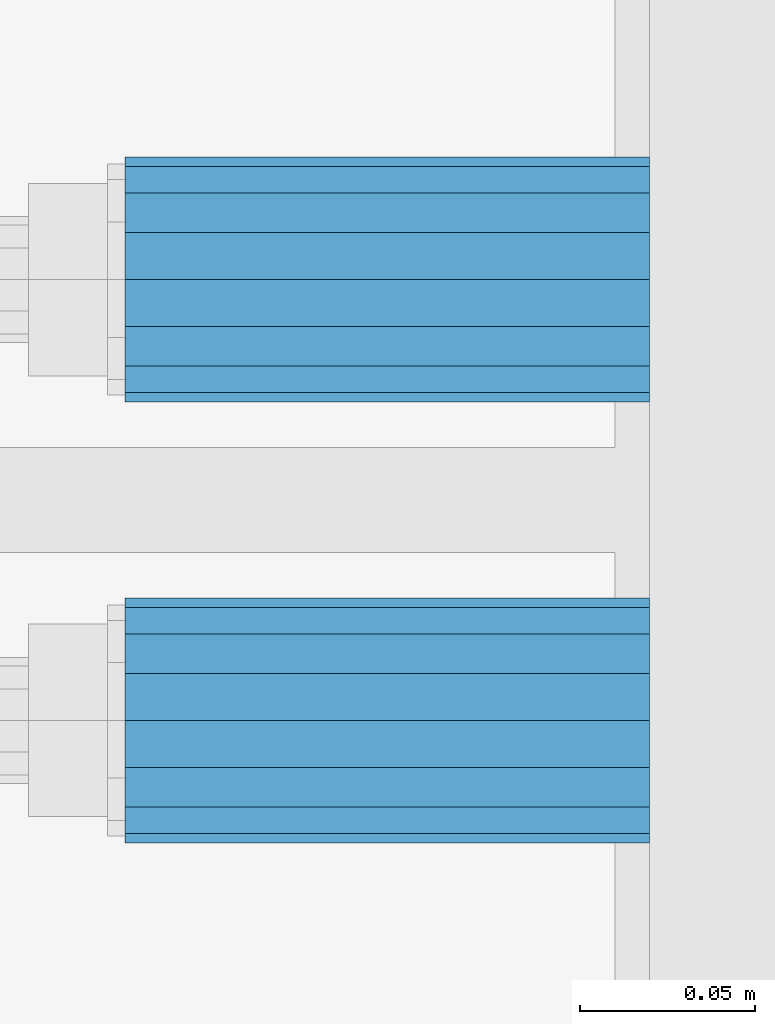
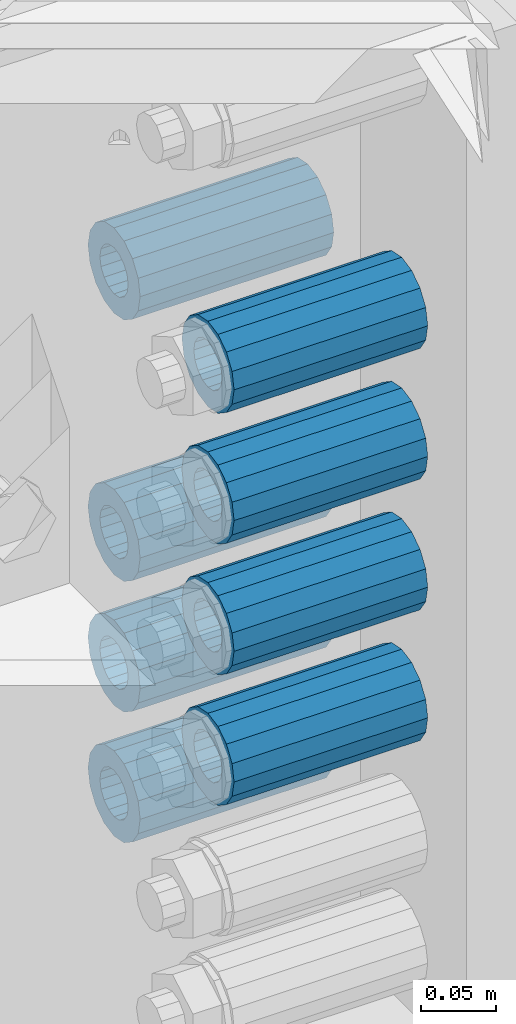
# One storey, part 133 of 208: 8 beams.
"""IFC2X3 building model written with IfcOpenShell, lengths in millimetres."""

import ifcopenshell
import ifcopenshell.guid

model = None  # the IFC model being written
_history = None  # IfcOwnerHistory: only IFC2X3 demands one
_inside = {}  # id of a spatial element -> (the spatial element, [elements in it])
_under = {}  # id of a project, library or spatial element -> (it, [spatial elements below it])
_declared = {}  # id of a project -> (the project, [libraries it declares])
_typed = {}  # id of a type object -> (the type object, [elements of that type])
_made_of = {}  # id of a material, layer set ... -> (it, [elements and type objects made of it])


def new_model(schema):
    """Start an empty IFC model of exactly this schema.

    Asked for "IFC4X3", IfcOpenShell would pick the latest addendum, in which some entities
    have other attributes; the version numbers below select the first issue.
    IFC2X3 requires an IfcOwnerHistory on every rooted entity: one is made here for all.
    """
    global model, _history
    if schema == "IFC4X3":
        model = ifcopenshell.file(schema_version=(4, 3, 0, 0))
    else:
        model = ifcopenshell.file(schema=schema)
    _inside.clear()
    _under.clear()
    _declared.clear()
    _typed.clear()
    _made_of.clear()
    _history = None
    if model.schema == "IFC2X3":
        org = make("IfcOrganization", Name="unknown")
        user = make(
            "IfcPersonAndOrganization",
            ThePerson=make("IfcPerson", FamilyName="unknown"),
            TheOrganization=org,
        )
        app = make(
            "IfcApplication",
            ApplicationDeveloper=org,
            Version="unknown",
            ApplicationFullName="unknown",
            ApplicationIdentifier="unknown",
        )
        _history = make(
            "IfcOwnerHistory",
            OwningUser=user,
            OwningApplication=app,
            ChangeAction="ADDED",
            CreationDate=0,
        )
    return model


def make(cls, **values):
    """One entity of the class cls with the attributes given. An attribute that is None is left unset."""
    return model.create_entity(
        cls, **{name: value for name, value in values.items() if value is not None}
    )


def rooted(cls, **values):
    """An entity with a GlobalId (a new one), such as an element, a storey or a relation."""
    return make(cls, GlobalId=ifcopenshell.guid.new(), OwnerHistory=_history, **values)


def si_unit(unit_type, name, prefix=None):
    """IfcSIUnit, for example si_unit("LENGTHUNIT", "METRE", prefix="MILLI")."""
    return make("IfcSIUnit", UnitType=unit_type, Prefix=prefix, Name=name)


def assignment(units):
    """IfcUnitAssignment: the units of a project."""
    return None if units is None else make("IfcUnitAssignment", Units=units)


def point(xyz):
    """IfcCartesianPoint."""
    return None if xyz is None else make("IfcCartesianPoint", Coordinates=xyz)


def direction(xyz):
    """IfcDirection."""
    return None if xyz is None else make("IfcDirection", DirectionRatios=xyz)


def frame(location, z_axis=None, x_axis=None):
    """IfcAxis2Placement3D, a coordinate frame: its origin and axes. An axis left out is left unset."""
    return make(
        "IfcAxis2Placement3D",
        Location=point(location),
        Axis=direction(z_axis),
        RefDirection=direction(x_axis),
    )


def origin_with_axes():
    """The frame at (0, 0, 0) with the z axis (0, 0, 1) and the x axis (1, 0, 0) written out."""
    return frame((0.0, 0.0, 0.0), z_axis=(0.0, 0.0, 1.0), x_axis=(1.0, 0.0, 0.0))


def place(relative_to, where):
    """IfcLocalPlacement: puts the frame where relative to a parent placement (None: the world)."""
    return make(
        "IfcLocalPlacement", PlacementRelTo=relative_to, RelativePlacement=where
    )


def context(
    kind, dimensions, precision=None, world=None, true_north=None, identifier=None
):
    """IfcGeometricRepresentationContext, for example the 3D "Model" context."""
    return make(
        "IfcGeometricRepresentationContext",
        ContextIdentifier=identifier,
        ContextType=kind,
        CoordinateSpaceDimension=dimensions,
        Precision=precision,
        WorldCoordinateSystem=world,
        TrueNorth=true_north,
    )


def subcontext(parent, identifier, kind, view, scale=None):
    """IfcGeometricRepresentationSubContext, for example "Body" below "Model"."""
    return make(
        "IfcGeometricRepresentationSubContext",
        ContextIdentifier=identifier,
        ContextType=kind,
        ParentContext=parent,
        TargetScale=scale,
        TargetView=view,
    )


def project(units=None, contexts=None):
    """IfcProject with its units and contexts."""
    return rooted(
        "IfcProject",
        Name="project",
        RepresentationContexts=contexts,
        UnitsInContext=assignment(units),
    )


def spatial(cls, under=None, at=None, **own):
    """A site, building, storey or space (cls), placed at a placement, below another one or the project."""
    s = rooted(cls, ObjectPlacement=at, **own)
    if under is not None:
        _under.setdefault(under.id(), (under, []))[1].append(s)
    return s


def faces_of(points, faces, orient=None, outer=None):
    """IfcFace entities. A face is a list of loops; a loop is a list of indices into points, from 0.

    orient and outer hold one flag for each loop. By default every Orientation is true, the
    first loop of a face is its IfcFaceOuterBound and the others are IfcFaceBound.
    """
    made = []
    for i, loops in enumerate(faces):
        bounds = []
        for j, loop in enumerate(loops):
            is_outer = j == 0 if outer is None else outer[i][j]
            bounds.append(
                make(
                    "IfcFaceOuterBound" if is_outer else "IfcFaceBound",
                    Bound=make("IfcPolyLoop", Polygon=[points[k] for k in loop]),
                    Orientation=True if orient is None else orient[i][j],
                )
            )
        made.append(make("IfcFace", Bounds=bounds))
    return made


def faceted_brep(points, faces, orient=None, outer=None, voids=None):
    """IfcFacetedBrep: a solid bounded by flat faces; with voids (closed shells), ...WithVoids."""
    shared = [point(p) for p in points]
    hull = make("IfcClosedShell", CfsFaces=faces_of(shared, faces, orient, outer))
    if voids is None:
        return make("IfcFacetedBrep", Outer=hull)
    return make(
        "IfcFacetedBrepWithVoids",
        Outer=hull,
        Voids=[
            make(cls, CfsFaces=faces_of(shared, fs, o, b)) for cls, fs, o, b in voids
        ],
    )


def shape(context_of_items, identifier, shape_type, items):
    """IfcShapeRepresentation: the items that make up one representation, for example the "Body"."""
    return make(
        "IfcShapeRepresentation",
        ContextOfItems=context_of_items,
        RepresentationIdentifier=identifier,
        RepresentationType=shape_type,
        Items=items,
    )


def material(Name=None, Category=None):
    """IfcMaterial."""
    return make("IfcMaterial", Name=Name, Category=Category)


def made_of(thing, what):
    """Note that an element or type object is made of a material, layer set ...; save() writes the relation."""
    if what is not None:
        _made_of.setdefault(what.id(), (what, []))[1].append(thing)
    return thing


def type_object(cls, material=None, **own):
    """A type object (cls), such as IfcWallType, which elements share."""
    return made_of(rooted(cls, **own), material)


def element(
    cls,
    number,
    at=None,
    inside=None,
    cuts=None,
    type_object=None,
    material=None,
    context=None,
    identifier="Body",
    shape_type=None,
    held_by="IfcProductDefinitionShape",
    body=None,
    shapes=None,
    **own,
):
    """One element of the class cls, such as IfcWall. Its Tag is "e" and its number.

    at: its placement. inside: the storey or other place that contains it. cuts: it is an
    opening in that element (IfcRelVoidsElement). A single representation is given by context,
    identifier, shape_type and body (its items); several are given by shapes. held_by: the class
    of the entity that holds the representations. save() writes the other relations.
    """
    e = rooted(cls, Tag="e%d" % number, ObjectPlacement=at, **own)
    if body is not None:
        shapes = [shape(context, identifier, shape_type, body)]
    if shapes is not None:
        e.Representation = make(held_by, Representations=shapes)
    if inside is not None:
        _inside.setdefault(inside.id(), (inside, []))[1].append(e)
    if cuts is not None:
        rooted(
            "IfcRelVoidsElement", RelatingBuildingElement=cuts, RelatedOpeningElement=e
        )
    if type_object is not None:
        _typed.setdefault(type_object.id(), (type_object, []))[1].append(e)
    return made_of(e, material)


def aggregate(whole, parts):
    """IfcRelAggregates: a whole, such as a stair, and the parts it consists of."""
    return rooted("IfcRelAggregates", RelatingObject=whole, RelatedObjects=parts)


def save(model, path):
    """Write the relations noted so far, then the file.

    IfcRelAggregates (storeys below a building ...), IfcRelContainedInSpatialStructure (elements
    in a storey), IfcRelDefinesByType, IfcRelAssociatesMaterial and IfcRelDeclares: one each for
    every whole, place, type object, material and project.
    """
    for whole, parts in _under.values():
        aggregate(whole, parts)
    for where, things in _inside.values():
        rooted(
            "IfcRelContainedInSpatialStructure",
            RelatedElements=things,
            RelatingStructure=where,
        )
    for kind, things in _typed.values():
        rooted("IfcRelDefinesByType", RelatedObjects=things, RelatingType=kind)
    for what, things in _made_of.values():
        rooted("IfcRelAssociatesMaterial", RelatedObjects=things, RelatingMaterial=what)
    for by, libraries in _declared.values():
        rooted("IfcRelDeclares", RelatingContext=by, RelatedDefinitions=libraries)
    model.write(path)


model = new_model("IFC2X3")

# Units and contexts
model_context = context("Model", 3, precision=1e-05, world=origin_with_axes())
body_context = subcontext(model_context, "Body", "Model", "MODEL_VIEW")
ifc_project = project(units=[si_unit("LENGTHUNIT", "METRE", prefix="MILLI"), si_unit("AREAUNIT", "SQUARE_METRE"), si_unit("VOLUMEUNIT", "CUBIC_METRE"), si_unit("MASSUNIT", "GRAM", prefix="KILO"), si_unit("TIMEUNIT", "SECOND"), si_unit("PLANEANGLEUNIT", "RADIAN"), si_unit("SOLIDANGLEUNIT", "STERADIAN"), si_unit("THERMODYNAMICTEMPERATUREUNIT", "DEGREE_CELSIUS"), si_unit("LUMINOUSINTENSITYUNIT", "LUMEN")], contexts=[model_context])

# Site, building, storey
site_placement = place(None, origin_with_axes())
site = spatial("IfcSite", under=ifc_project, at=site_placement, CompositionType="ELEMENT")
building_placement = place(site_placement, origin_with_axes())
building = spatial("IfcBuilding", under=site, at=building_placement, Name="Standard", CompositionType="ELEMENT")
storey_placement = place(building_placement, origin_with_axes())
storey = spatial("IfcBuildingStorey", under=building, at=storey_placement, Name="Undefined", CompositionType="ELEMENT", Elevation=0.0)

# Beams
ifc_material = material()
beam_type = type_object("IfcBeamType", PredefinedType="NOTDEFINED")
beam_1_placement = place(storey_placement, frame((-25783.0, 2937.0, -392.0), z_axis=(0.0, 0.0, 1.0), x_axis=(1.0, 0.0, 0.0)))
element("IfcBeam", 1, at=beam_1_placement, inside=storey, type_object=beam_type, material=ifc_material, context=body_context, shape_type="Brep", body=[
    faceted_brep([(-1.3120632047503e-07, -18.9999999995496, -6.26459950581193e-09), (0.0, -17.5537111177146, 7.27098521493672), (150.0, -17.5537111177146, 7.27098521493672), (150.0, -19.0, 0.0), (0.0, -13.4350288425444, 13.4350288425444), (150.0, -13.4350288425444, 13.4350288425444), (0.0, -7.2709852149369, 17.5537111177144), (150.0, -7.2709852149369, 17.5537111177144), (-6.33906438451959e-09, 4.50199877377599e-10, 18.9999999937354), (150.0, 0.0, 19.0), (0.0, 7.2709852149369, 17.5537111177144), (150.0, 7.2709852149369, 17.5537111177144), (0.0, 13.4350288425444, 13.4350288425444), (150.0, 13.4350288425444, 13.4350288425444), (0.0, 17.5537111177146, 7.2709852149367), (150.0, 17.5537111177146, 7.2709852149367), (1.33208345687308e-07, 19.0000000004507, -6.26459950581193e-09), (150.0, 19.0, 0.0), (0.0, 17.5537111177146, -7.2709852149367), (150.0, 17.5537111177146, -7.2709852149367), (0.0, 13.4350288425444, -13.4350288425444), (150.0, 13.4350288425444, -13.4350288425444), (0.0, 7.2709852149369, -17.5537111177144), (150.0, 7.2709852149369, -17.5537111177144), (8.34120328363497e-09, 4.50427251053043e-10, -19.0000000062646), (150.0, 0.0, -19.0), (0.0, -7.2709852149369, -17.5537111177144), (150.0, -7.2709852149369, -17.5537111177144), (0.0, -13.4350288425444, -13.4350288425444), (150.0, -13.4350288425444, -13.4350288425444), (0.0, -17.5537111177146, -7.2709852149367), (150.0, -17.5537111177146, -7.2709852149367), (0.0, -35.0, 0.0), (-3.63797880709171e-12, -32.335783637895, -13.3939201327782), (150.0, -32.335783637895, -13.3939201327782), (150.0, -35.0, 0.0), (0.0, -24.7487373415292, -24.7487373415291), (150.0, -24.7487373415293, -24.7487373415292), (0.0, -13.3939201327781, -32.335783637895), (150.0, -13.393920132778, -32.335783637895), (0.0, 0.0, -35.0), (150.0, 0.0, -35.0), (0.0, 13.3939201327782, -32.335783637895), (150.0, 13.393920132778, -32.335783637895), (0.0, 24.7487373415292, -24.7487373415291), (150.0, 24.7487373415293, -24.7487373415292), (-3.63797880709171e-12, 32.335783637895, -13.3939201327782), (150.0, 32.335783637895, -13.3939201327781), (0.0, 35.0, 0.0), (150.0, 35.0, 0.0), (0.0, 32.335783637895, 13.3939201327781), (150.0, 32.335783637895, 13.3939201327781), (0.0, 24.7487373415292, 24.748737341529), (150.0, 24.7487373415293, 24.7487373415292), (0.0, 13.3939201327781, 32.335783637895), (150.0, 13.393920132778, 32.335783637895), (-3.63797880709171e-12, 0.0, 35.0), (150.0, 0.0, 35.0), (0.0, -13.3939201327781, 32.335783637895), (150.0, -13.393920132778, 32.335783637895), (0.0, -24.7487373415292, 24.748737341529), (150.0, -24.7487373415293, 24.7487373415292), (0.0, -32.335783637895, 13.3939201327781), (150.0, -32.335783637895, 13.3939201327781)], [[[0, 1, 2, 3]], [[1, 4, 5, 2]], [[4, 6, 7, 5]], [[6, 8, 9, 7]], [[8, 10, 11, 9]], [[10, 12, 13, 11]], [[12, 14, 15, 13]], [[14, 16, 17, 15]], [[16, 18, 19, 17]], [[18, 20, 21, 19]], [[20, 22, 23, 21]], [[22, 24, 25, 23]], [[24, 26, 27, 25]], [[26, 28, 29, 27]], [[28, 30, 31, 29]], [[30, 0, 3, 31]], [[32, 33, 34, 35]], [[33, 36, 37, 34]], [[36, 38, 39, 37]], [[38, 40, 41, 39]], [[40, 42, 43, 41]], [[42, 44, 45, 43]], [[44, 46, 47, 45]], [[46, 48, 49, 47]], [[48, 50, 51, 49]], [[50, 52, 53, 51]], [[52, 54, 55, 53]], [[54, 56, 57, 55]], [[56, 58, 59, 57]], [[58, 60, 61, 59]], [[60, 62, 63, 61]], [[62, 32, 35, 63]], [[37, 39, 41, 43, 45, 47, 49, 51, 53, 55, 57, 59, 61, 63, 35, 34], [5, 7, 9, 11, 13, 15, 17, 19, 21, 23, 25, 27, 29, 31, 3, 2]], [[62, 60, 58, 56, 54, 52, 50, 48, 46, 44, 42, 40, 38, 36, 33, 32], [30, 28, 26, 24, 22, 20, 18, 16, 14, 12, 10, 8, 6, 4, 1, 0]]]),
])
beam_2_placement = place(storey_placement, frame((-25783.0, 3063.0, -606.0), z_axis=(0.0, 0.0, 1.0), x_axis=(1.0, 0.0, 0.0)))
element("IfcBeam", 2, at=beam_2_placement, inside=storey, type_object=beam_type, material=ifc_material, context=body_context, shape_type="Brep", body=[
    faceted_brep([(-1.3120632047503e-07, -18.9999999995496, -6.26459950581193e-09), (0.0, -17.5537111177146, 7.27098521493672), (150.0, -17.5537111177146, 7.27098521493672), (150.0, -19.0, 0.0), (0.0, -13.4350288425444, 13.4350288425444), (150.0, -13.4350288425444, 13.4350288425444), (0.0, -7.2709852149369, 17.5537111177144), (150.0, -7.2709852149369, 17.5537111177144), (-6.33906438451959e-09, 4.50199877377599e-10, 18.9999999937354), (150.0, 0.0, 19.0), (0.0, 7.2709852149369, 17.5537111177144), (150.0, 7.2709852149369, 17.5537111177144), (0.0, 13.4350288425444, 13.4350288425444), (150.0, 13.4350288425444, 13.4350288425444), (0.0, 17.5537111177146, 7.2709852149367), (150.0, 17.5537111177146, 7.2709852149367), (1.33208345687308e-07, 19.0000000004507, -6.26459950581193e-09), (150.0, 19.0, 0.0), (0.0, 17.5537111177146, -7.2709852149367), (150.0, 17.5537111177146, -7.2709852149367), (0.0, 13.4350288425444, -13.4350288425444), (150.0, 13.4350288425444, -13.4350288425444), (0.0, 7.2709852149369, -17.5537111177144), (150.0, 7.2709852149369, -17.5537111177144), (8.34120328363497e-09, 4.50427251053043e-10, -19.0000000062646), (150.0, 0.0, -19.0), (0.0, -7.2709852149369, -17.5537111177144), (150.0, -7.2709852149369, -17.5537111177144), (0.0, -13.4350288425444, -13.4350288425444), (150.0, -13.4350288425444, -13.4350288425444), (0.0, -17.5537111177146, -7.2709852149367), (150.0, -17.5537111177146, -7.2709852149367), (0.0, -35.0, 0.0), (-3.63797880709171e-12, -32.335783637895, -13.3939201327782), (150.0, -32.335783637895, -13.3939201327782), (150.0, -35.0, 0.0), (0.0, -24.7487373415292, -24.7487373415291), (150.0, -24.7487373415293, -24.7487373415292), (0.0, -13.3939201327781, -32.335783637895), (150.0, -13.393920132778, -32.335783637895), (0.0, 0.0, -35.0), (150.0, 0.0, -35.0), (0.0, 13.3939201327782, -32.335783637895), (150.0, 13.393920132778, -32.335783637895), (0.0, 24.7487373415292, -24.7487373415291), (150.0, 24.7487373415293, -24.7487373415292), (-3.63797880709171e-12, 32.335783637895, -13.3939201327782), (150.0, 32.335783637895, -13.3939201327781), (0.0, 35.0, 0.0), (150.0, 35.0, 0.0), (0.0, 32.335783637895, 13.3939201327781), (150.0, 32.335783637895, 13.3939201327781), (0.0, 24.7487373415292, 24.748737341529), (150.0, 24.7487373415293, 24.7487373415292), (0.0, 13.3939201327781, 32.335783637895), (150.0, 13.393920132778, 32.335783637895), (-3.63797880709171e-12, 0.0, 35.0), (150.0, 0.0, 35.0), (0.0, -13.3939201327781, 32.335783637895), (150.0, -13.393920132778, 32.335783637895), (0.0, -24.7487373415292, 24.748737341529), (150.0, -24.7487373415293, 24.7487373415292), (0.0, -32.335783637895, 13.3939201327781), (150.0, -32.335783637895, 13.3939201327781)], [[[0, 1, 2, 3]], [[1, 4, 5, 2]], [[4, 6, 7, 5]], [[6, 8, 9, 7]], [[8, 10, 11, 9]], [[10, 12, 13, 11]], [[12, 14, 15, 13]], [[14, 16, 17, 15]], [[16, 18, 19, 17]], [[18, 20, 21, 19]], [[20, 22, 23, 21]], [[22, 24, 25, 23]], [[24, 26, 27, 25]], [[26, 28, 29, 27]], [[28, 30, 31, 29]], [[30, 0, 3, 31]], [[32, 33, 34, 35]], [[33, 36, 37, 34]], [[36, 38, 39, 37]], [[38, 40, 41, 39]], [[40, 42, 43, 41]], [[42, 44, 45, 43]], [[44, 46, 47, 45]], [[46, 48, 49, 47]], [[48, 50, 51, 49]], [[50, 52, 53, 51]], [[52, 54, 55, 53]], [[54, 56, 57, 55]], [[56, 58, 59, 57]], [[58, 60, 61, 59]], [[60, 62, 63, 61]], [[62, 32, 35, 63]], [[37, 39, 41, 43, 45, 47, 49, 51, 53, 55, 57, 59, 61, 63, 35, 34], [5, 7, 9, 11, 13, 15, 17, 19, 21, 23, 25, 27, 29, 31, 3, 2]], [[62, 60, 58, 56, 54, 52, 50, 48, 46, 44, 42, 40, 38, 36, 33, 32], [30, 28, 26, 24, 22, 20, 18, 16, 14, 12, 10, 8, 6, 4, 1, 0]]]),
])
beam_3_placement = place(storey_placement, frame((-25783.0, 3063.0, -499.0), z_axis=(0.0, 0.0, 1.0), x_axis=(1.0, 0.0, 0.0)))
element("IfcBeam", 3, at=beam_3_placement, inside=storey, type_object=beam_type, material=ifc_material, context=body_context, shape_type="Brep", body=[
    faceted_brep([(-1.3120632047503e-07, -18.9999999995496, -6.26459950581193e-09), (0.0, -17.5537111177146, 7.27098521493672), (150.0, -17.5537111177146, 7.27098521493672), (150.0, -19.0, 0.0), (0.0, -13.4350288425444, 13.4350288425444), (150.0, -13.4350288425444, 13.4350288425444), (0.0, -7.2709852149369, 17.5537111177144), (150.0, -7.2709852149369, 17.5537111177144), (-6.33906438451959e-09, 4.50199877377599e-10, 18.9999999937354), (150.0, 0.0, 19.0), (0.0, 7.2709852149369, 17.5537111177144), (150.0, 7.2709852149369, 17.5537111177144), (0.0, 13.4350288425444, 13.4350288425444), (150.0, 13.4350288425444, 13.4350288425444), (0.0, 17.5537111177146, 7.2709852149367), (150.0, 17.5537111177146, 7.2709852149367), (1.33208345687308e-07, 19.0000000004507, -6.26459950581193e-09), (150.0, 19.0, 0.0), (0.0, 17.5537111177146, -7.2709852149367), (150.0, 17.5537111177146, -7.2709852149367), (0.0, 13.4350288425444, -13.4350288425444), (150.0, 13.4350288425444, -13.4350288425444), (0.0, 7.2709852149369, -17.5537111177144), (150.0, 7.2709852149369, -17.5537111177144), (8.34120328363497e-09, 4.50427251053043e-10, -19.0000000062646), (150.0, 0.0, -19.0), (0.0, -7.2709852149369, -17.5537111177144), (150.0, -7.2709852149369, -17.5537111177144), (0.0, -13.4350288425444, -13.4350288425444), (150.0, -13.4350288425444, -13.4350288425444), (0.0, -17.5537111177146, -7.2709852149367), (150.0, -17.5537111177146, -7.2709852149367), (0.0, -35.0, 0.0), (-3.63797880709171e-12, -32.335783637895, -13.3939201327782), (150.0, -32.335783637895, -13.3939201327782), (150.0, -35.0, 0.0), (0.0, -24.7487373415292, -24.7487373415291), (150.0, -24.7487373415293, -24.7487373415292), (0.0, -13.3939201327781, -32.335783637895), (150.0, -13.393920132778, -32.335783637895), (0.0, 0.0, -35.0), (150.0, 0.0, -35.0), (0.0, 13.3939201327782, -32.335783637895), (150.0, 13.393920132778, -32.335783637895), (0.0, 24.7487373415292, -24.7487373415291), (150.0, 24.7487373415293, -24.7487373415292), (-3.63797880709171e-12, 32.335783637895, -13.3939201327782), (150.0, 32.335783637895, -13.3939201327781), (0.0, 35.0, 0.0), (150.0, 35.0, 0.0), (0.0, 32.335783637895, 13.3939201327781), (150.0, 32.335783637895, 13.3939201327781), (0.0, 24.7487373415292, 24.748737341529), (150.0, 24.7487373415293, 24.7487373415292), (0.0, 13.3939201327781, 32.335783637895), (150.0, 13.393920132778, 32.335783637895), (-3.63797880709171e-12, 0.0, 35.0), (150.0, 0.0, 35.0), (0.0, -13.3939201327781, 32.335783637895), (150.0, -13.393920132778, 32.335783637895), (0.0, -24.7487373415292, 24.748737341529), (150.0, -24.7487373415293, 24.7487373415292), (0.0, -32.335783637895, 13.3939201327781), (150.0, -32.335783637895, 13.3939201327781)], [[[0, 1, 2, 3]], [[1, 4, 5, 2]], [[4, 6, 7, 5]], [[6, 8, 9, 7]], [[8, 10, 11, 9]], [[10, 12, 13, 11]], [[12, 14, 15, 13]], [[14, 16, 17, 15]], [[16, 18, 19, 17]], [[18, 20, 21, 19]], [[20, 22, 23, 21]], [[22, 24, 25, 23]], [[24, 26, 27, 25]], [[26, 28, 29, 27]], [[28, 30, 31, 29]], [[30, 0, 3, 31]], [[32, 33, 34, 35]], [[33, 36, 37, 34]], [[36, 38, 39, 37]], [[38, 40, 41, 39]], [[40, 42, 43, 41]], [[42, 44, 45, 43]], [[44, 46, 47, 45]], [[46, 48, 49, 47]], [[48, 50, 51, 49]], [[50, 52, 53, 51]], [[52, 54, 55, 53]], [[54, 56, 57, 55]], [[56, 58, 59, 57]], [[58, 60, 61, 59]], [[60, 62, 63, 61]], [[62, 32, 35, 63]], [[37, 39, 41, 43, 45, 47, 49, 51, 53, 55, 57, 59, 61, 63, 35, 34], [5, 7, 9, 11, 13, 15, 17, 19, 21, 23, 25, 27, 29, 31, 3, 2]], [[62, 60, 58, 56, 54, 52, 50, 48, 46, 44, 42, 40, 38, 36, 33, 32], [30, 28, 26, 24, 22, 20, 18, 16, 14, 12, 10, 8, 6, 4, 1, 0]]]),
])
beam_4_placement = place(storey_placement, frame((-25783.0, 3063.0, -285.0), z_axis=(0.0, 0.0, 1.0), x_axis=(1.0, 0.0, 0.0)))
element("IfcBeam", 4, at=beam_4_placement, inside=storey, type_object=beam_type, material=ifc_material, context=body_context, shape_type="Brep", body=[
    faceted_brep([(-1.3120632047503e-07, -18.9999999995496, -6.26459950581193e-09), (0.0, -17.5537111177146, 7.27098521493672), (150.0, -17.5537111177146, 7.27098521493672), (150.0, -19.0, 0.0), (0.0, -13.4350288425444, 13.4350288425444), (150.0, -13.4350288425444, 13.4350288425444), (0.0, -7.2709852149369, 17.5537111177144), (150.0, -7.2709852149369, 17.5537111177144), (-6.33906438451959e-09, 4.50199877377599e-10, 18.9999999937354), (150.0, 0.0, 19.0), (0.0, 7.2709852149369, 17.5537111177144), (150.0, 7.2709852149369, 17.5537111177144), (0.0, 13.4350288425444, 13.4350288425444), (150.0, 13.4350288425444, 13.4350288425444), (0.0, 17.5537111177146, 7.2709852149367), (150.0, 17.5537111177146, 7.2709852149367), (1.33208345687308e-07, 19.0000000004507, -6.26459950581193e-09), (150.0, 19.0, 0.0), (0.0, 17.5537111177146, -7.2709852149367), (150.0, 17.5537111177146, -7.2709852149367), (0.0, 13.4350288425444, -13.4350288425444), (150.0, 13.4350288425444, -13.4350288425444), (0.0, 7.2709852149369, -17.5537111177144), (150.0, 7.2709852149369, -17.5537111177144), (8.34120328363497e-09, 4.50427251053043e-10, -19.0000000062646), (150.0, 0.0, -19.0), (0.0, -7.2709852149369, -17.5537111177144), (150.0, -7.2709852149369, -17.5537111177144), (0.0, -13.4350288425444, -13.4350288425444), (150.0, -13.4350288425444, -13.4350288425444), (0.0, -17.5537111177146, -7.2709852149367), (150.0, -17.5537111177146, -7.2709852149367), (0.0, -35.0, 0.0), (-3.63797880709171e-12, -32.335783637895, -13.3939201327782), (150.0, -32.335783637895, -13.3939201327782), (150.0, -35.0, 0.0), (0.0, -24.7487373415292, -24.7487373415291), (150.0, -24.7487373415293, -24.7487373415292), (0.0, -13.3939201327781, -32.335783637895), (150.0, -13.393920132778, -32.335783637895), (0.0, 0.0, -35.0), (150.0, 0.0, -35.0), (0.0, 13.3939201327782, -32.335783637895), (150.0, 13.393920132778, -32.335783637895), (0.0, 24.7487373415292, -24.7487373415291), (150.0, 24.7487373415293, -24.7487373415292), (-3.63797880709171e-12, 32.335783637895, -13.3939201327782), (150.0, 32.335783637895, -13.3939201327781), (0.0, 35.0, 0.0), (150.0, 35.0, 0.0), (0.0, 32.335783637895, 13.3939201327781), (150.0, 32.335783637895, 13.3939201327781), (0.0, 24.7487373415292, 24.748737341529), (150.0, 24.7487373415293, 24.7487373415292), (0.0, 13.3939201327781, 32.335783637895), (150.0, 13.393920132778, 32.335783637895), (-3.63797880709171e-12, 0.0, 35.0), (150.0, 0.0, 35.0), (0.0, -13.3939201327781, 32.335783637895), (150.0, -13.393920132778, 32.335783637895), (0.0, -24.7487373415292, 24.748737341529), (150.0, -24.7487373415293, 24.7487373415292), (0.0, -32.335783637895, 13.3939201327781), (150.0, -32.335783637895, 13.3939201327781)], [[[0, 1, 2, 3]], [[1, 4, 5, 2]], [[4, 6, 7, 5]], [[6, 8, 9, 7]], [[8, 10, 11, 9]], [[10, 12, 13, 11]], [[12, 14, 15, 13]], [[14, 16, 17, 15]], [[16, 18, 19, 17]], [[18, 20, 21, 19]], [[20, 22, 23, 21]], [[22, 24, 25, 23]], [[24, 26, 27, 25]], [[26, 28, 29, 27]], [[28, 30, 31, 29]], [[30, 0, 3, 31]], [[32, 33, 34, 35]], [[33, 36, 37, 34]], [[36, 38, 39, 37]], [[38, 40, 41, 39]], [[40, 42, 43, 41]], [[42, 44, 45, 43]], [[44, 46, 47, 45]], [[46, 48, 49, 47]], [[48, 50, 51, 49]], [[50, 52, 53, 51]], [[52, 54, 55, 53]], [[54, 56, 57, 55]], [[56, 58, 59, 57]], [[58, 60, 61, 59]], [[60, 62, 63, 61]], [[62, 32, 35, 63]], [[37, 39, 41, 43, 45, 47, 49, 51, 53, 55, 57, 59, 61, 63, 35, 34], [5, 7, 9, 11, 13, 15, 17, 19, 21, 23, 25, 27, 29, 31, 3, 2]], [[62, 60, 58, 56, 54, 52, 50, 48, 46, 44, 42, 40, 38, 36, 33, 32], [30, 28, 26, 24, 22, 20, 18, 16, 14, 12, 10, 8, 6, 4, 1, 0]]]),
])
beam_5_placement = place(storey_placement, frame((-25783.0, 2937.0, -285.0), z_axis=(0.0, 0.0, 1.0), x_axis=(1.0, 0.0, 0.0)))
element("IfcBeam", 5, at=beam_5_placement, inside=storey, type_object=beam_type, material=ifc_material, context=body_context, shape_type="Brep", body=[
    faceted_brep([(-1.3120632047503e-07, -18.9999999995496, -6.26459950581193e-09), (0.0, -17.5537111177146, 7.27098521493672), (150.0, -17.5537111177146, 7.27098521493672), (150.0, -19.0, 0.0), (0.0, -13.4350288425444, 13.4350288425444), (150.0, -13.4350288425444, 13.4350288425444), (0.0, -7.2709852149369, 17.5537111177144), (150.0, -7.2709852149369, 17.5537111177144), (-6.33906438451959e-09, 4.50199877377599e-10, 18.9999999937354), (150.0, 0.0, 19.0), (0.0, 7.2709852149369, 17.5537111177144), (150.0, 7.2709852149369, 17.5537111177144), (0.0, 13.4350288425444, 13.4350288425444), (150.0, 13.4350288425444, 13.4350288425444), (0.0, 17.5537111177146, 7.2709852149367), (150.0, 17.5537111177146, 7.2709852149367), (1.33208345687308e-07, 19.0000000004507, -6.26459950581193e-09), (150.0, 19.0, 0.0), (0.0, 17.5537111177146, -7.2709852149367), (150.0, 17.5537111177146, -7.2709852149367), (0.0, 13.4350288425444, -13.4350288425444), (150.0, 13.4350288425444, -13.4350288425444), (0.0, 7.2709852149369, -17.5537111177144), (150.0, 7.2709852149369, -17.5537111177144), (8.34120328363497e-09, 4.50427251053043e-10, -19.0000000062646), (150.0, 0.0, -19.0), (0.0, -7.2709852149369, -17.5537111177144), (150.0, -7.2709852149369, -17.5537111177144), (0.0, -13.4350288425444, -13.4350288425444), (150.0, -13.4350288425444, -13.4350288425444), (0.0, -17.5537111177146, -7.2709852149367), (150.0, -17.5537111177146, -7.2709852149367), (0.0, -35.0, 0.0), (-3.63797880709171e-12, -32.335783637895, -13.3939201327782), (150.0, -32.335783637895, -13.3939201327782), (150.0, -35.0, 0.0), (0.0, -24.7487373415292, -24.7487373415291), (150.0, -24.7487373415293, -24.7487373415292), (0.0, -13.3939201327781, -32.335783637895), (150.0, -13.393920132778, -32.335783637895), (0.0, 0.0, -35.0), (150.0, 0.0, -35.0), (0.0, 13.3939201327782, -32.335783637895), (150.0, 13.393920132778, -32.335783637895), (0.0, 24.7487373415292, -24.7487373415291), (150.0, 24.7487373415293, -24.7487373415292), (-3.63797880709171e-12, 32.335783637895, -13.3939201327782), (150.0, 32.335783637895, -13.3939201327781), (0.0, 35.0, 0.0), (150.0, 35.0, 0.0), (0.0, 32.335783637895, 13.3939201327781), (150.0, 32.335783637895, 13.3939201327781), (0.0, 24.7487373415292, 24.748737341529), (150.0, 24.7487373415293, 24.7487373415292), (0.0, 13.3939201327781, 32.335783637895), (150.0, 13.393920132778, 32.335783637895), (-3.63797880709171e-12, 0.0, 35.0), (150.0, 0.0, 35.0), (0.0, -13.3939201327781, 32.335783637895), (150.0, -13.393920132778, 32.335783637895), (0.0, -24.7487373415292, 24.748737341529), (150.0, -24.7487373415293, 24.7487373415292), (0.0, -32.335783637895, 13.3939201327781), (150.0, -32.335783637895, 13.3939201327781)], [[[0, 1, 2, 3]], [[1, 4, 5, 2]], [[4, 6, 7, 5]], [[6, 8, 9, 7]], [[8, 10, 11, 9]], [[10, 12, 13, 11]], [[12, 14, 15, 13]], [[14, 16, 17, 15]], [[16, 18, 19, 17]], [[18, 20, 21, 19]], [[20, 22, 23, 21]], [[22, 24, 25, 23]], [[24, 26, 27, 25]], [[26, 28, 29, 27]], [[28, 30, 31, 29]], [[30, 0, 3, 31]], [[32, 33, 34, 35]], [[33, 36, 37, 34]], [[36, 38, 39, 37]], [[38, 40, 41, 39]], [[40, 42, 43, 41]], [[42, 44, 45, 43]], [[44, 46, 47, 45]], [[46, 48, 49, 47]], [[48, 50, 51, 49]], [[50, 52, 53, 51]], [[52, 54, 55, 53]], [[54, 56, 57, 55]], [[56, 58, 59, 57]], [[58, 60, 61, 59]], [[60, 62, 63, 61]], [[62, 32, 35, 63]], [[37, 39, 41, 43, 45, 47, 49, 51, 53, 55, 57, 59, 61, 63, 35, 34], [5, 7, 9, 11, 13, 15, 17, 19, 21, 23, 25, 27, 29, 31, 3, 2]], [[62, 60, 58, 56, 54, 52, 50, 48, 46, 44, 42, 40, 38, 36, 33, 32], [30, 28, 26, 24, 22, 20, 18, 16, 14, 12, 10, 8, 6, 4, 1, 0]]]),
])
beam_6_placement = place(storey_placement, frame((-25783.0, 2937.0, -499.0), z_axis=(0.0, 0.0, 1.0), x_axis=(1.0, 0.0, 0.0)))
element("IfcBeam", 6, at=beam_6_placement, inside=storey, type_object=beam_type, material=ifc_material, context=body_context, shape_type="Brep", body=[
    faceted_brep([(-1.3120632047503e-07, -18.9999999995496, -6.26459950581193e-09), (0.0, -17.5537111177146, 7.27098521493672), (150.0, -17.5537111177146, 7.27098521493672), (150.0, -19.0, 0.0), (0.0, -13.4350288425444, 13.4350288425444), (150.0, -13.4350288425444, 13.4350288425444), (0.0, -7.2709852149369, 17.5537111177144), (150.0, -7.2709852149369, 17.5537111177144), (-6.33906438451959e-09, 4.50199877377599e-10, 18.9999999937354), (150.0, 0.0, 19.0), (0.0, 7.2709852149369, 17.5537111177144), (150.0, 7.2709852149369, 17.5537111177144), (0.0, 13.4350288425444, 13.4350288425444), (150.0, 13.4350288425444, 13.4350288425444), (0.0, 17.5537111177146, 7.2709852149367), (150.0, 17.5537111177146, 7.2709852149367), (1.33208345687308e-07, 19.0000000004507, -6.26459950581193e-09), (150.0, 19.0, 0.0), (0.0, 17.5537111177146, -7.2709852149367), (150.0, 17.5537111177146, -7.2709852149367), (0.0, 13.4350288425444, -13.4350288425444), (150.0, 13.4350288425444, -13.4350288425444), (0.0, 7.2709852149369, -17.5537111177144), (150.0, 7.2709852149369, -17.5537111177144), (8.34120328363497e-09, 4.50427251053043e-10, -19.0000000062646), (150.0, 0.0, -19.0), (0.0, -7.2709852149369, -17.5537111177144), (150.0, -7.2709852149369, -17.5537111177144), (0.0, -13.4350288425444, -13.4350288425444), (150.0, -13.4350288425444, -13.4350288425444), (0.0, -17.5537111177146, -7.2709852149367), (150.0, -17.5537111177146, -7.2709852149367), (0.0, -35.0, 0.0), (-3.63797880709171e-12, -32.335783637895, -13.3939201327782), (150.0, -32.335783637895, -13.3939201327782), (150.0, -35.0, 0.0), (0.0, -24.7487373415292, -24.7487373415291), (150.0, -24.7487373415293, -24.7487373415292), (0.0, -13.3939201327781, -32.335783637895), (150.0, -13.393920132778, -32.335783637895), (0.0, 0.0, -35.0), (150.0, 0.0, -35.0), (0.0, 13.3939201327782, -32.335783637895), (150.0, 13.393920132778, -32.335783637895), (0.0, 24.7487373415292, -24.7487373415291), (150.0, 24.7487373415293, -24.7487373415292), (-3.63797880709171e-12, 32.335783637895, -13.3939201327782), (150.0, 32.335783637895, -13.3939201327781), (0.0, 35.0, 0.0), (150.0, 35.0, 0.0), (0.0, 32.335783637895, 13.3939201327781), (150.0, 32.335783637895, 13.3939201327781), (0.0, 24.7487373415292, 24.748737341529), (150.0, 24.7487373415293, 24.7487373415292), (0.0, 13.3939201327781, 32.335783637895), (150.0, 13.393920132778, 32.335783637895), (-3.63797880709171e-12, 0.0, 35.0), (150.0, 0.0, 35.0), (0.0, -13.3939201327781, 32.335783637895), (150.0, -13.393920132778, 32.335783637895), (0.0, -24.7487373415292, 24.748737341529), (150.0, -24.7487373415293, 24.7487373415292), (0.0, -32.335783637895, 13.3939201327781), (150.0, -32.335783637895, 13.3939201327781)], [[[0, 1, 2, 3]], [[1, 4, 5, 2]], [[4, 6, 7, 5]], [[6, 8, 9, 7]], [[8, 10, 11, 9]], [[10, 12, 13, 11]], [[12, 14, 15, 13]], [[14, 16, 17, 15]], [[16, 18, 19, 17]], [[18, 20, 21, 19]], [[20, 22, 23, 21]], [[22, 24, 25, 23]], [[24, 26, 27, 25]], [[26, 28, 29, 27]], [[28, 30, 31, 29]], [[30, 0, 3, 31]], [[32, 33, 34, 35]], [[33, 36, 37, 34]], [[36, 38, 39, 37]], [[38, 40, 41, 39]], [[40, 42, 43, 41]], [[42, 44, 45, 43]], [[44, 46, 47, 45]], [[46, 48, 49, 47]], [[48, 50, 51, 49]], [[50, 52, 53, 51]], [[52, 54, 55, 53]], [[54, 56, 57, 55]], [[56, 58, 59, 57]], [[58, 60, 61, 59]], [[60, 62, 63, 61]], [[62, 32, 35, 63]], [[37, 39, 41, 43, 45, 47, 49, 51, 53, 55, 57, 59, 61, 63, 35, 34], [5, 7, 9, 11, 13, 15, 17, 19, 21, 23, 25, 27, 29, 31, 3, 2]], [[62, 60, 58, 56, 54, 52, 50, 48, 46, 44, 42, 40, 38, 36, 33, 32], [30, 28, 26, 24, 22, 20, 18, 16, 14, 12, 10, 8, 6, 4, 1, 0]]]),
])
beam_7_placement = place(storey_placement, frame((-25783.0, 2937.0, -606.0), z_axis=(0.0, 0.0, 1.0), x_axis=(1.0, 0.0, 0.0)))
element("IfcBeam", 7, at=beam_7_placement, inside=storey, type_object=beam_type, material=ifc_material, context=body_context, shape_type="Brep", body=[
    faceted_brep([(-1.3120632047503e-07, -18.9999999995496, -6.26459950581193e-09), (0.0, -17.5537111177146, 7.27098521493672), (150.0, -17.5537111177146, 7.27098521493672), (150.0, -19.0, 0.0), (0.0, -13.4350288425444, 13.4350288425444), (150.0, -13.4350288425444, 13.4350288425444), (0.0, -7.2709852149369, 17.5537111177144), (150.0, -7.2709852149369, 17.5537111177144), (-6.33906438451959e-09, 4.50199877377599e-10, 18.9999999937354), (150.0, 0.0, 19.0), (0.0, 7.2709852149369, 17.5537111177144), (150.0, 7.2709852149369, 17.5537111177144), (0.0, 13.4350288425444, 13.4350288425444), (150.0, 13.4350288425444, 13.4350288425444), (0.0, 17.5537111177146, 7.2709852149367), (150.0, 17.5537111177146, 7.2709852149367), (1.33208345687308e-07, 19.0000000004507, -6.26459950581193e-09), (150.0, 19.0, 0.0), (0.0, 17.5537111177146, -7.2709852149367), (150.0, 17.5537111177146, -7.2709852149367), (0.0, 13.4350288425444, -13.4350288425444), (150.0, 13.4350288425444, -13.4350288425444), (0.0, 7.2709852149369, -17.5537111177144), (150.0, 7.2709852149369, -17.5537111177144), (8.34120328363497e-09, 4.50427251053043e-10, -19.0000000062646), (150.0, 0.0, -19.0), (0.0, -7.2709852149369, -17.5537111177144), (150.0, -7.2709852149369, -17.5537111177144), (0.0, -13.4350288425444, -13.4350288425444), (150.0, -13.4350288425444, -13.4350288425444), (0.0, -17.5537111177146, -7.2709852149367), (150.0, -17.5537111177146, -7.2709852149367), (0.0, -35.0, 0.0), (-3.63797880709171e-12, -32.335783637895, -13.3939201327782), (150.0, -32.335783637895, -13.3939201327782), (150.0, -35.0, 0.0), (0.0, -24.7487373415292, -24.7487373415291), (150.0, -24.7487373415293, -24.7487373415292), (0.0, -13.3939201327781, -32.335783637895), (150.0, -13.393920132778, -32.335783637895), (0.0, 0.0, -35.0), (150.0, 0.0, -35.0), (0.0, 13.3939201327782, -32.335783637895), (150.0, 13.393920132778, -32.335783637895), (0.0, 24.7487373415292, -24.7487373415291), (150.0, 24.7487373415293, -24.7487373415292), (-3.63797880709171e-12, 32.335783637895, -13.3939201327782), (150.0, 32.335783637895, -13.3939201327781), (0.0, 35.0, 0.0), (150.0, 35.0, 0.0), (0.0, 32.335783637895, 13.3939201327781), (150.0, 32.335783637895, 13.3939201327781), (0.0, 24.7487373415292, 24.748737341529), (150.0, 24.7487373415293, 24.7487373415292), (0.0, 13.3939201327781, 32.335783637895), (150.0, 13.393920132778, 32.335783637895), (-3.63797880709171e-12, 0.0, 35.0), (150.0, 0.0, 35.0), (0.0, -13.3939201327781, 32.335783637895), (150.0, -13.393920132778, 32.335783637895), (0.0, -24.7487373415292, 24.748737341529), (150.0, -24.7487373415293, 24.7487373415292), (0.0, -32.335783637895, 13.3939201327781), (150.0, -32.335783637895, 13.3939201327781)], [[[0, 1, 2, 3]], [[1, 4, 5, 2]], [[4, 6, 7, 5]], [[6, 8, 9, 7]], [[8, 10, 11, 9]], [[10, 12, 13, 11]], [[12, 14, 15, 13]], [[14, 16, 17, 15]], [[16, 18, 19, 17]], [[18, 20, 21, 19]], [[20, 22, 23, 21]], [[22, 24, 25, 23]], [[24, 26, 27, 25]], [[26, 28, 29, 27]], [[28, 30, 31, 29]], [[30, 0, 3, 31]], [[32, 33, 34, 35]], [[33, 36, 37, 34]], [[36, 38, 39, 37]], [[38, 40, 41, 39]], [[40, 42, 43, 41]], [[42, 44, 45, 43]], [[44, 46, 47, 45]], [[46, 48, 49, 47]], [[48, 50, 51, 49]], [[50, 52, 53, 51]], [[52, 54, 55, 53]], [[54, 56, 57, 55]], [[56, 58, 59, 57]], [[58, 60, 61, 59]], [[60, 62, 63, 61]], [[62, 32, 35, 63]], [[37, 39, 41, 43, 45, 47, 49, 51, 53, 55, 57, 59, 61, 63, 35, 34], [5, 7, 9, 11, 13, 15, 17, 19, 21, 23, 25, 27, 29, 31, 3, 2]], [[62, 60, 58, 56, 54, 52, 50, 48, 46, 44, 42, 40, 38, 36, 33, 32], [30, 28, 26, 24, 22, 20, 18, 16, 14, 12, 10, 8, 6, 4, 1, 0]]]),
])
beam_8_placement = place(storey_placement, frame((-25783.0, 3063.0, -713.0), z_axis=(0.0, 0.0, 1.0), x_axis=(1.0, 0.0, 0.0)))
element("IfcBeam", 8, at=beam_8_placement, inside=storey, type_object=beam_type, material=ifc_material, context=body_context, shape_type="Brep", body=[
    faceted_brep([(-1.3120632047503e-07, -18.9999999995496, -6.26459950581193e-09), (0.0, -17.5537111177146, 7.27098521493672), (150.0, -17.5537111177146, 7.27098521493672), (150.0, -19.0, 0.0), (0.0, -13.4350288425444, 13.4350288425444), (150.0, -13.4350288425444, 13.4350288425444), (0.0, -7.2709852149369, 17.5537111177144), (150.0, -7.2709852149369, 17.5537111177144), (-6.33906438451959e-09, 4.50199877377599e-10, 18.9999999937354), (150.0, 0.0, 19.0), (0.0, 7.2709852149369, 17.5537111177144), (150.0, 7.2709852149369, 17.5537111177144), (0.0, 13.4350288425444, 13.4350288425444), (150.0, 13.4350288425444, 13.4350288425444), (0.0, 17.5537111177146, 7.2709852149367), (150.0, 17.5537111177146, 7.2709852149367), (1.33208345687308e-07, 19.0000000004507, -6.26459950581193e-09), (150.0, 19.0, 0.0), (0.0, 17.5537111177146, -7.2709852149367), (150.0, 17.5537111177146, -7.2709852149367), (0.0, 13.4350288425444, -13.4350288425444), (150.0, 13.4350288425444, -13.4350288425444), (0.0, 7.2709852149369, -17.5537111177144), (150.0, 7.2709852149369, -17.5537111177144), (8.34120328363497e-09, 4.50427251053043e-10, -19.0000000062646), (150.0, 0.0, -19.0), (0.0, -7.2709852149369, -17.5537111177144), (150.0, -7.2709852149369, -17.5537111177144), (0.0, -13.4350288425444, -13.4350288425444), (150.0, -13.4350288425444, -13.4350288425444), (0.0, -17.5537111177146, -7.2709852149367), (150.0, -17.5537111177146, -7.2709852149367), (0.0, -35.0, 0.0), (-3.63797880709171e-12, -32.335783637895, -13.3939201327782), (150.0, -32.335783637895, -13.3939201327782), (150.0, -35.0, 0.0), (0.0, -24.7487373415292, -24.7487373415291), (150.0, -24.7487373415293, -24.7487373415292), (0.0, -13.3939201327781, -32.335783637895), (150.0, -13.393920132778, -32.335783637895), (0.0, 0.0, -35.0), (150.0, 0.0, -35.0), (0.0, 13.3939201327782, -32.335783637895), (150.0, 13.393920132778, -32.335783637895), (0.0, 24.7487373415292, -24.7487373415291), (150.0, 24.7487373415293, -24.7487373415292), (-3.63797880709171e-12, 32.335783637895, -13.3939201327782), (150.0, 32.335783637895, -13.3939201327781), (0.0, 35.0, 0.0), (150.0, 35.0, 0.0), (0.0, 32.335783637895, 13.3939201327781), (150.0, 32.335783637895, 13.3939201327781), (0.0, 24.7487373415292, 24.748737341529), (150.0, 24.7487373415293, 24.7487373415292), (0.0, 13.3939201327781, 32.335783637895), (150.0, 13.393920132778, 32.335783637895), (-3.63797880709171e-12, 0.0, 35.0), (150.0, 0.0, 35.0), (0.0, -13.3939201327781, 32.335783637895), (150.0, -13.393920132778, 32.335783637895), (0.0, -24.7487373415292, 24.748737341529), (150.0, -24.7487373415293, 24.7487373415292), (0.0, -32.335783637895, 13.3939201327781), (150.0, -32.335783637895, 13.3939201327781)], [[[0, 1, 2, 3]], [[1, 4, 5, 2]], [[4, 6, 7, 5]], [[6, 8, 9, 7]], [[8, 10, 11, 9]], [[10, 12, 13, 11]], [[12, 14, 15, 13]], [[14, 16, 17, 15]], [[16, 18, 19, 17]], [[18, 20, 21, 19]], [[20, 22, 23, 21]], [[22, 24, 25, 23]], [[24, 26, 27, 25]], [[26, 28, 29, 27]], [[28, 30, 31, 29]], [[30, 0, 3, 31]], [[32, 33, 34, 35]], [[33, 36, 37, 34]], [[36, 38, 39, 37]], [[38, 40, 41, 39]], [[40, 42, 43, 41]], [[42, 44, 45, 43]], [[44, 46, 47, 45]], [[46, 48, 49, 47]], [[48, 50, 51, 49]], [[50, 52, 53, 51]], [[52, 54, 55, 53]], [[54, 56, 57, 55]], [[56, 58, 59, 57]], [[58, 60, 61, 59]], [[60, 62, 63, 61]], [[62, 32, 35, 63]], [[37, 39, 41, 43, 45, 47, 49, 51, 53, 55, 57, 59, 61, 63, 35, 34], [5, 7, 9, 11, 13, 15, 17, 19, 21, 23, 25, 27, 29, 31, 3, 2]], [[62, 60, 58, 56, 54, 52, 50, 48, 46, 44, 42, 40, 38, 36, 33, 32], [30, 28, 26, 24, 22, 20, 18, 16, 14, 12, 10, 8, 6, 4, 1, 0]]]),
])

save(model, "model.ifc")
